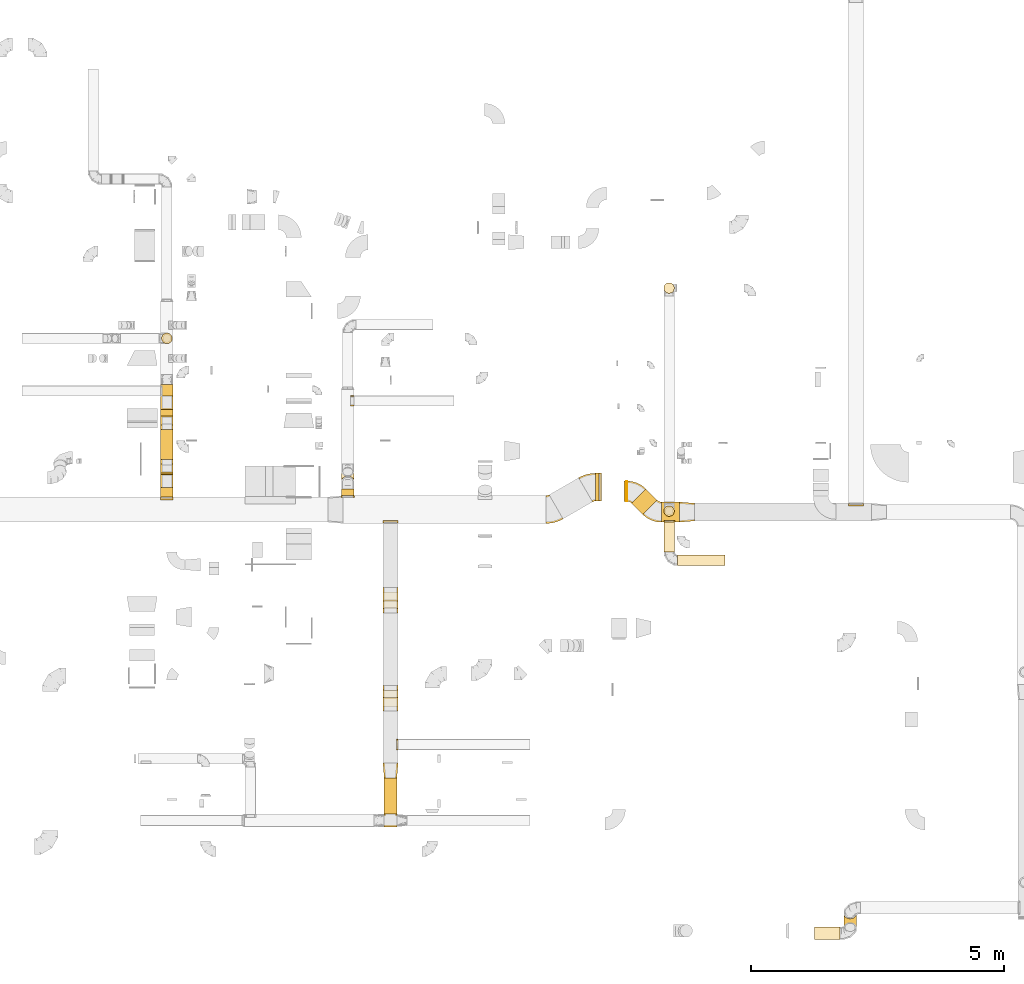
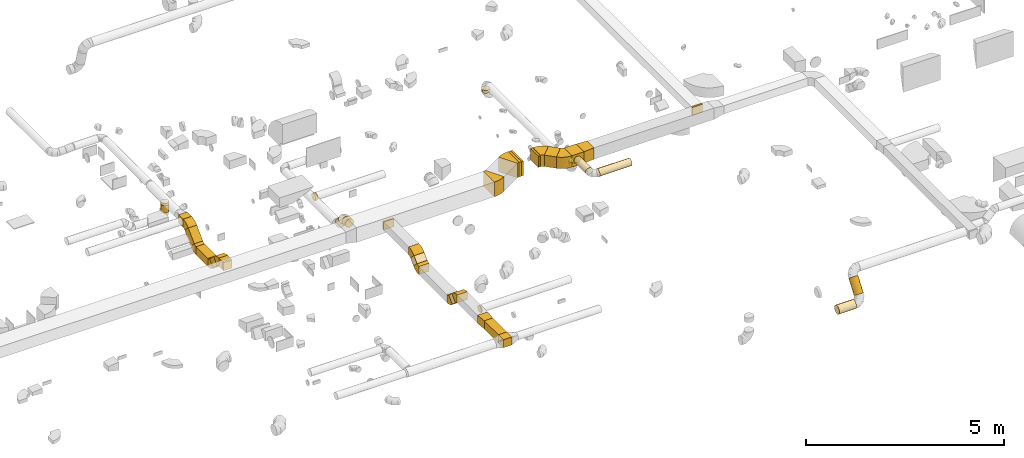
# One storey, part 3 of 62: 47 coverings.
"""IFC2X3 building model written with IfcOpenShell, lengths in millimetres."""

from ifc_helpers import new_model, entity, si_unit, converted_unit, derived_unit, direction, frame, frame_2d, origin, origin_2d_with_axis, place, context, subcontext, project, spatial, polyline, circle_curve, parameter, trimmed, segment, composite_curve, rectangle, circle, outline, extrude, element, save


model = new_model("IFC2X3")

# Units and contexts
model_context = context("Model", 3, precision=0.01, world=origin(), true_north=direction((6.12303176911189e-17, 1.0)))
body_context = subcontext(model_context, "Body", "Model", "MODEL_VIEW")
ifc_project = project(units=[si_unit("LENGTHUNIT", "METRE", prefix="MILLI"), si_unit("AREAUNIT", "SQUARE_METRE"), si_unit("VOLUMEUNIT", "CUBIC_METRE"), converted_unit("PLANEANGLEUNIT", "DEGREE", entity("IfcRatioMeasure", 0.0174532925199433), si_unit("PLANEANGLEUNIT", "RADIAN"), dimensions=[0, 0, 0, 0, 0, 0, 0]), si_unit("MASSUNIT", "GRAM", prefix="KILO"), derived_unit("MASSDENSITYUNIT", [(si_unit("MASSUNIT", "GRAM", prefix="KILO"), 1), (si_unit("LENGTHUNIT", "METRE"), -3)]), derived_unit("MOMENTOFINERTIAUNIT", [(si_unit("LENGTHUNIT", "METRE"), 4)]), si_unit("TIMEUNIT", "SECOND"), si_unit("FREQUENCYUNIT", "HERTZ"), si_unit("THERMODYNAMICTEMPERATUREUNIT", "DEGREE_CELSIUS"), derived_unit("THERMALTRANSMITTANCEUNIT", [(si_unit("MASSUNIT", "GRAM", prefix="KILO"), 1), (si_unit("THERMODYNAMICTEMPERATUREUNIT", "KELVIN"), -1), (si_unit("TIMEUNIT", "SECOND"), -3)]), derived_unit("VOLUMETRICFLOWRATEUNIT", [(si_unit("LENGTHUNIT", "METRE"), 3), (si_unit("TIMEUNIT", "SECOND"), -1)]), derived_unit("MASSFLOWRATEUNIT", [(si_unit("MASSUNIT", "GRAM", prefix="KILO"), 1), (si_unit("TIMEUNIT", "SECOND"), -1)]), derived_unit("ROTATIONALFREQUENCYUNIT", [(si_unit("TIMEUNIT", "SECOND"), -1)]), si_unit("ELECTRICCURRENTUNIT", "AMPERE"), si_unit("ELECTRICVOLTAGEUNIT", "VOLT"), si_unit("POWERUNIT", "WATT"), si_unit("FORCEUNIT", "NEWTON", prefix="KILO"), si_unit("ILLUMINANCEUNIT", "LUX"), si_unit("LUMINOUSFLUXUNIT", "LUMEN"), si_unit("LUMINOUSINTENSITYUNIT", "CANDELA"), derived_unit("USERDEFINED", [(si_unit("MASSUNIT", "GRAM", prefix="KILO"), -1), (si_unit("LENGTHUNIT", "METRE"), -2), (si_unit("TIMEUNIT", "SECOND"), 3), (si_unit("LUMINOUSFLUXUNIT", "LUMEN"), 1)]), derived_unit("LINEARVELOCITYUNIT", [(si_unit("LENGTHUNIT", "METRE"), 1), (si_unit("TIMEUNIT", "SECOND"), -1)]), si_unit("PRESSUREUNIT", "PASCAL"), derived_unit("USERDEFINED", [(si_unit("LENGTHUNIT", "METRE"), -2), (si_unit("MASSUNIT", "GRAM", prefix="KILO"), 1), (si_unit("TIMEUNIT", "SECOND"), -2)]), derived_unit("LINEARFORCEUNIT", [(si_unit("MASSUNIT", "GRAM", prefix="KILO"), 1), (si_unit("LENGTHUNIT", "METRE"), 1), (si_unit("TIMEUNIT", "SECOND"), -2), (si_unit("LENGTHUNIT", "METRE"), -1)]), derived_unit("PLANARFORCEUNIT", [(si_unit("MASSUNIT", "GRAM", prefix="KILO"), 1), (si_unit("LENGTHUNIT", "METRE"), 1), (si_unit("TIMEUNIT", "SECOND"), -2), (si_unit("LENGTHUNIT", "METRE"), -2)])], contexts=[model_context])

# Site, building, storey
site_placement = place(None, origin())
site = spatial("IfcSite", under=ifc_project, at=site_placement, CompositionType="ELEMENT")
building_placement = place(site_placement, origin())
building = spatial("IfcBuilding", under=site, at=building_placement, CompositionType="ELEMENT")
storey_placement = place(building_placement, frame((0.0, 0.0, 24000.0)))
storey = spatial("IfcBuildingStorey", under=building, at=storey_placement, CompositionType="ELEMENT", Elevation=24000.0)

# Coverings
covering_1_placement = place(storey_placement, frame((59305.64, 9093.57, 3325.0)))
element("IfcCovering", 1, at=covering_1_placement, inside=storey, PredefinedType="INSULATION", context=body_context, shape_type="SweptSolid", body=[
    extrude(rectangle(XDim=550.000000000001, YDim=51.0960000000016, at=origin_2d_with_axis()), frame((25.55, 275.0, 0.0), z_axis=(0.0, 0.0, 1.0), x_axis=(0.0, -1.0, 0.0)), (0.0, 0.0, 1.0), 450.000000000002),
])
covering_2_placement = place(storey_placement, frame((59237.24, 9093.57, 3325.0)))
element("IfcCovering", 2, at=covering_2_placement, inside=storey, PredefinedType="INSULATION", context=body_context, shape_type="SweptSolid", body=[
    extrude(rectangle(XDim=68.403733792958, YDim=550.000000000001, at=origin_2d_with_axis()), frame((34.2, 275.0, 0.0), z_axis=(0.0, 0.0, 1.0), x_axis=(-1.0, 0.0, 0.0)), (0.0, 0.0, 1.0), 450.000000000002),
])
covering_3_placement = place(storey_placement, frame((55054.59, 2900.97, 3425.0)))
element("IfcCovering", 3, at=covering_3_placement, inside=storey, PredefinedType="INSULATION", context=body_context, shape_type="SweptSolid", body=[
    extrude(rectangle(XDim=711.276811598477, YDim=249.999999999995, at=origin_2d_with_axis()), frame((125.0, 355.64, 0.0), z_axis=(0.0, 0.0, 1.0), x_axis=(0.0, -1.0, 0.0)), (0.0, 0.0, 1.0), 250.000000000004),
])
covering_4_placement = place(storey_placement, frame((55029.59, 3612.24, 3425.0)))
element("IfcCovering", 4, at=covering_4_placement, inside=storey, PredefinedType="INSULATION", context=body_context, shape_type="SweptSolid", body=[
    extrude(outline(polyline([(-139.1, -137.03), (161.94, -137.03), (137.03, 161.94), (-159.86, 112.11), (-139.1, -137.03)])), frame((150.0, 150.0, 0.0), z_axis=(0.0, 0.0, 1.0), x_axis=(0.0830454798539784, 0.99654575824486, 0.0)), (0.0, 0.0, 1.0), 250.000000000004),
])
covering_5_placement = place(storey_placement, frame((55029.59, 8654.98, 3425.0)))
element("IfcCovering", 5, at=covering_5_placement, inside=storey, PredefinedType="INSULATION", context=body_context, shape_type="SweptSolid", body=[
    extrude(rectangle(XDim=300.000000000001, YDim=51.096000000008, at=origin_2d_with_axis()), frame((150.0, 25.55, 0.0)), (0.0, 0.0, 1.0), 250.000000000004),
])
covering_6_placement = place(storey_placement, frame((55029.59, 6967.61, 3234.83)))
element("IfcCovering", 6, at=covering_6_placement, inside=storey, PredefinedType="INSULATION", context=body_context, shape_type="SweptSolid", body=[
    extrude(rectangle(XDim=217.157287525396, YDim=249.999999999997, at=origin_2d_with_axis()), frame((0.0, 165.17, 165.17), z_axis=(1.0, 0.0, 0.0), x_axis=(0.0, -0.707106781186548, -0.707106781186548)), (0.0, 0.0, 1.0), 300.000000000001),
])
covering_7_placement = place(storey_placement, frame((55029.59, 5029.69, 3234.83)))
element("IfcCovering", 7, at=covering_7_placement, inside=storey, PredefinedType="INSULATION", context=body_context, shape_type="SweptSolid", body=[
    extrude(rectangle(XDim=217.157287525369, YDim=250.0, at=origin_2d_with_axis()), frame((0.0, 165.17, 165.17), z_axis=(1.0, 0.0, 0.0), x_axis=(0.0, 0.7071067811865, -0.707106781186595)), (0.0, 0.0, 1.0), 300.00000000001),
])
covering_8_placement = place(storey_placement, frame((55298.49, 4170.65, 3443.4)))
element("IfcCovering", 8, at=covering_8_placement, inside=storey, PredefinedType="INSULATION", context=body_context, shape_type="SweptSolid", body=[
    extrude(circle(Radius=105.0, at=origin_2d_with_axis()), frame((0.0, 106.6, 106.6), z_axis=(1.0, 0.0, 0.0), x_axis=(0.0, 1.0, 0.0)), (0.0, 0.0, 1.0), 26.0960000002065),
])
covering_9_placement = place(storey_placement, frame((50631.62, 9913.65, 3075.0)))
element("IfcCovering", 9, at=covering_9_placement, inside=storey, PredefinedType="INSULATION", context=body_context, shape_type="SweptSolid", body=[
    extrude(rectangle(XDim=597.695447254163, YDim=249.999999999995, at=origin_2d_with_axis()), frame((125.0, 298.85, 0.0), z_axis=(0.0, 0.0, 1.0), x_axis=(0.0, 1.0, 0.0)), (0.0, 0.0, 1.0), 250.000000000004),
])
covering_10_placement = place(storey_placement, frame((50631.62, 9118.88, 3425.0)))
element("IfcCovering", 10, at=covering_10_placement, inside=storey, PredefinedType="INSULATION", context=body_context, shape_type="SweptSolid", body=[
    extrude(rectangle(XDim=250.000000000004, YDim=51.0960000000427, at=origin_2d_with_axis()), frame((125.0, 25.55, 0.0), z_axis=(0.0, 0.0, 1.0), x_axis=(-1.0, 0.0, 0.0)), (0.0, 0.0, 1.0), 250.000000000004),
])
covering_11_placement = place(storey_placement, frame((50631.62, 9169.98, 3425.0)))
element("IfcCovering", 11, at=covering_11_placement, inside=storey, PredefinedType="INSULATION", context=body_context, shape_type="SweptSolid", body=[
    extrude(rectangle(XDim=186.566609406722, YDim=249.999999999995, at=origin_2d_with_axis()), frame((125.0, 93.28, 0.0), z_axis=(0.0, 0.0, 1.0), x_axis=(0.0, 1.0, 0.0)), (0.0, 0.0, 1.0), 250.000000000004),
])
covering_12_placement = place(storey_placement, frame((50631.62, 9444.93, 3184.83)))
element("IfcCovering", 12, at=covering_12_placement, inside=storey, PredefinedType="INSULATION", context=body_context, shape_type="SweptSolid", body=[
    extrude(rectangle(XDim=249.999999999998, YDim=249.999999999995, at=frame_2d((0.0, 0.0), x_axis=(0.0, 1.0))), frame((125.0, 291.94, 88.39), z_axis=(0.0, -0.707106781186508, 0.707106781186587), x_axis=(-1.0, 0.0, 0.0)), (0.0, 0.0, 1.0), 287.867965643983),
])
covering_13_placement = place(storey_placement, frame((50631.62, 11168.45, 3525.0)))
element("IfcCovering", 13, at=covering_13_placement, inside=storey, PredefinedType="INSULATION", context=body_context, shape_type="SweptSolid", body=[
    extrude(rectangle(XDim=227.123541719797, YDim=249.999999999995, at=origin_2d_with_axis()), frame((125.0, 113.56, 0.0), z_axis=(0.0, 0.0, 1.0), x_axis=(0.0, -1.0, 0.0)), (0.0, 0.0, 1.0), 250.000000000004),
])
covering_14_placement = place(storey_placement, frame((50631.62, 10599.73, 3184.83)))
element("IfcCovering", 14, at=covering_14_placement, inside=storey, PredefinedType="INSULATION", context=body_context, shape_type="SweptSolid", body=[
    extrude(rectangle(XDim=249.999999999995, YDim=249.999999999995, at=frame_2d((0.0, 0.0), x_axis=(0.0, 1.0))), frame((125.0, 88.39, 88.39), z_axis=(0.0, 0.707106781186517, 0.707106781186578), x_axis=(1.0, 0.0, 0.0)), (0.0, 0.0, 1.0), 429.289321881387),
])
covering_15_placement = place(storey_placement, frame((50650.03, 12203.45, 3300.0)))
element("IfcCovering", 15, at=covering_15_placement, inside=storey, PredefinedType="INSULATION", context=body_context, shape_type="SweptSolid", body=[
    extrude(circle(Radius=105.0, at=origin_2d_with_axis()), frame((106.6, 106.6, 0.0), z_axis=(0.0, 0.0, 1.0), x_axis=(0.0, -1.0, 0.0)), (0.0, 0.0, 1.0), 230.000000000021),
])
covering_16_placement = place(storey_placement, frame((50650.03, 12203.45, 3530.0)))
element("IfcCovering", 16, at=covering_16_placement, inside=storey, PredefinedType="INSULATION", context=body_context, shape_type="SweptSolid", body=[
    extrude(circle(Radius=105.0, at=origin_2d_with_axis()), frame((106.6, 106.6, 0.0), z_axis=(0.0, 0.0, 1.0), x_axis=(0.0, 1.0, 0.0)), (0.0, 0.0, 1.0), 66.0960000000068),
])
covering_17_placement = place(storey_placement, frame((54206.92, 9389.54, 3189.5)))
element("IfcCovering", 17, at=covering_17_placement, inside=storey, PredefinedType="INSULATION", context=body_context, shape_type="SweptSolid", body=[
    extrude(circle(Radius=125.0, at=origin_2d_with_axis()), frame((126.6, 97.35, 302.72), z_axis=(0.0, 0.642787609686537, -0.76604444311898), x_axis=(1.0, 0.0, 0.0)), (0.0, 0.0, 1.0), 288.206572271397),
])
covering_18_placement = place(storey_placement, frame((54206.92, 9194.98, 3437.07)))
element("IfcCovering", 18, at=covering_18_placement, inside=storey, PredefinedType="INSULATION", context=body_context, shape_type="SweptSolid", body=[
    extrude(circle(Radius=125.0, at=origin_2d_with_axis()), frame((126.6, 0.0, 126.6), z_axis=(0.0, 1.0, 0.0), x_axis=(-1.0, 0.0, 0.0)), (0.0, 0.0, 1.0), 138.700860216017),
])
covering_19_placement = place(storey_placement, frame((54206.92, 9168.88, 3437.07)))
element("IfcCovering", 19, at=covering_19_placement, inside=storey, PredefinedType="INSULATION", context=body_context, shape_type="SweptSolid", body=[
    extrude(circle(Radius=125.0, at=origin_2d_with_axis()), frame((126.6, 0.0, 126.6), z_axis=(0.0, 1.0, 0.0), x_axis=(-1.0, 0.0, 0.0)), (0.0, 0.0, 1.0), 26.0959999999942),
])
covering_20_placement = place(storey_placement, frame((60539.45, 8675.02, 3425.0)))
element("IfcCovering", 20, at=covering_20_placement, inside=storey, PredefinedType="INSULATION", context=body_context, shape_type="SweptSolid", body=[
    extrude(rectangle(XDim=352.280592228734, YDim=400.0, at=origin_2d_with_axis()), frame((176.14, 200.0, 0.0), z_axis=(0.0, 0.0, 1.0), x_axis=(-1.0, 0.0, 0.0)), (0.0, 0.0, 1.0), 349.999999999998),
])
covering_21_placement = place(storey_placement, frame((60891.73, 8675.02, 3425.0)))
element("IfcCovering", 21, at=covering_21_placement, inside=storey, PredefinedType="INSULATION", context=body_context, shape_type="SweptSolid", body=[
    extrude(outline(polyline([(-166.09, -186.85), (134.95, -186.85), (164.01, 161.94), (-132.87, 211.77), (-166.09, -186.85)])), frame((150.0, 200.0, 0.0), z_axis=(0.0, 0.0, 1.0), x_axis=(0.996545758244898, 0.0830454798535232, 0.0)), (0.0, 0.0, 1.0), 349.999999999998),
])
covering_22_placement = place(storey_placement, frame((59845.64, 9088.12, 3425.0)))
element("IfcCovering", 22, at=covering_22_placement, inside=storey, PredefinedType="INSULATION", context=body_context, shape_type="SweptSolid", body=[
    extrude(rectangle(XDim=11.4684169262546, YDim=400.0, at=origin_2d_with_axis()), frame((5.73, 200.0, 0.0), z_axis=(0.0, 0.0, 1.0), x_axis=(-1.0, 0.0, 0.0)), (0.0, 0.0, 1.0), 349.999999999998),
])
covering_23_placement = place(storey_placement, frame((59945.5, 8828.79, 3425.0)))
element("IfcCovering", 23, at=covering_23_placement, inside=storey, PredefinedType="INSULATION", context=body_context, shape_type="SweptSolid", body=[
    extrude(rectangle(XDim=314.972807073821, YDim=400.000000000007, at=origin_2d_with_axis()), frame((252.78, 252.78, 0.0), z_axis=(0.0, 0.0, 1.0), x_axis=(-0.707106781186534, 0.707106781186561, 0.0)), (0.0, 0.0, 1.0), 349.999999999998),
])
covering_24_placement = place(storey_placement, frame((59794.55, 9088.12, 3425.0)))
element("IfcCovering", 24, at=covering_24_placement, inside=storey, PredefinedType="INSULATION", context=body_context, shape_type="SweptSolid", body=[
    extrude(rectangle(XDim=400.0, YDim=51.0960000000016, at=origin_2d_with_axis()), frame((25.55, 200.0, 0.0), z_axis=(0.0, 0.0, 1.0), x_axis=(0.0, 1.0, 0.0)), (0.0, 0.0, 1.0), 349.999999999998),
])
covering_25_placement = place(storey_placement, frame((60582.25, 8789.03, 3320.0)))
element("IfcCovering", 25, at=covering_25_placement, inside=storey, PredefinedType="INSULATION", context=body_context, shape_type="SweptSolid", body=[
    extrude(circle(Radius=105.0, at=origin_2d_with_axis()), frame((106.6, 106.6, 0.0), z_axis=(0.0, 0.0, 1.0), x_axis=(-1.0, 0.0, 0.0)), (0.0, 0.0, 1.0), 109.999999999901),
])
covering_26_placement = place(storey_placement, frame((60582.25, 8789.03, 3430.0)))
element("IfcCovering", 26, at=covering_26_placement, inside=storey, PredefinedType="INSULATION", context=body_context, shape_type="SweptSolid", body=[
    extrude(circle(Radius=105.0, at=origin_2d_with_axis()), frame((106.6, 106.6, 0.0), z_axis=(0.0, 0.0, 1.0), x_axis=(-1.0, 0.0, 0.0)), (0.0, 0.0, 1.0), 26.0960000002065),
])
covering_27_placement = place(storey_placement, frame((60856.21, 7819.07, 3493.4)))
element("IfcCovering", 27, at=covering_27_placement, inside=storey, PredefinedType="INSULATION", context=body_context, shape_type="SweptSolid", body=[
    extrude(circle(Radius=105.0, at=origin_2d_with_axis()), frame((0.0, 106.6, 106.6), z_axis=(1.0, 0.0, 0.0), x_axis=(0.0, -1.0, 0.0)), (0.0, 0.0, 1.0), 939.375000000018),
])
covering_28_placement = place(storey_placement, frame((60589.62, 8085.66, 3493.4)))
element("IfcCovering", 28, at=covering_28_placement, inside=storey, PredefinedType="INSULATION", context=body_context, shape_type="SweptSolid", body=[
    extrude(circle(Radius=105.0, at=origin_2d_with_axis()), frame((106.6, 0.0, 106.6), z_axis=(0.0, 1.0, 0.0), x_axis=(-1.0, 0.0, 0.0)), (0.0, 0.0, 1.0), 594.360142446069),
])
covering_29_placement = place(storey_placement, frame((60589.62, 8680.02, 3493.4)))
element("IfcCovering", 29, at=covering_29_placement, inside=storey, PredefinedType="INSULATION", context=body_context, shape_type="SweptSolid", body=[
    extrude(circle(Radius=105.0, at=origin_2d_with_axis()), frame((106.6, 0.0, 106.6), z_axis=(0.0, 1.0, 0.0), x_axis=(1.0, 0.0, 0.0)), (0.0, 0.0, 1.0), 26.0960000000365),
])
covering_30_placement = place(storey_placement, frame((64232.65, 8993.93, 3525.0)))
element("IfcCovering", 30, at=covering_30_placement, inside=storey, PredefinedType="INSULATION", context=body_context, shape_type="SweptSolid", body=[
    extrude(rectangle(XDim=51.0960000000113, YDim=300.000000000001, at=origin_2d_with_axis()), frame((150.0, 25.55, 0.0), z_axis=(0.0, 0.0, 1.0), x_axis=(0.0, -1.0, 0.0)), (0.0, 0.0, 1.0), 250.000000000004),
])
covering_31_placement = place(storey_placement, frame((55054.59, 2650.97, 3425.0)))
element("IfcCovering", 31, at=covering_31_placement, inside=storey, PredefinedType="INSULATION", context=body_context, shape_type="SweptSolid", body=[
    extrude(rectangle(XDim=249.999999999998, YDim=250.000000000004, at=origin_2d_with_axis()), frame((125.0, 125.0, 0.0), z_axis=(0.0, 0.0, 1.0), x_axis=(0.0, -1.0, 0.0)), (0.0, 0.0, 1.0), 250.000000000004),
])
covering_32_placement = place(storey_placement, frame((64143.27, 557.6, 2987.12)))
element("IfcCovering", 32, at=covering_32_placement, inside=storey, PredefinedType="INSULATION", context=body_context, shape_type="SweptSolid", body=[
    extrude(circle(Radius=125.0, at=origin_2d_with_axis()), frame((126.6, 102.85, 74.89), z_axis=(0.0, 0.586367683700161, 0.810045023138905), x_axis=(1.0, 0.0, 0.0)), (0.0, 0.0, 1.0), 464.149497873041),
])
covering_33_placement = place(storey_placement, frame((63567.37, 416.58, 2773.4)))
element("IfcCovering", 33, at=covering_33_placement, inside=storey, PredefinedType="INSULATION", context=body_context, shape_type="SweptSolid", body=[
    extrude(circle(Radius=125.0, at=origin_2d_with_axis()), frame((0.0, 126.6, 126.6), z_axis=(1.0, 0.0, 0.0), x_axis=(0.0, 1.0, 0.0)), (0.0, 0.0, 1.0), 502.500000000024),
])
covering_34_placement = place(storey_placement, frame((60582.25, 13199.03, 2910.0)))
element("IfcCovering", 34, at=covering_34_placement, inside=storey, PredefinedType="INSULATION", context=body_context, shape_type="SweptSolid", body=[
    extrude(circle(Radius=105.0, at=origin_2d_with_axis()), frame((106.6, 106.6, 0.0)), (0.0, 0.0, 1.0), 90.0000000000272),
])
covering_35_placement = place(storey_placement, frame((54387.42, 10971.22, 3093.4)))
element("IfcCovering", 35, at=covering_35_placement, inside=storey, PredefinedType="INSULATION", context=body_context, shape_type="SweptSolid", body=[
    extrude(circle(Radius=105.0, at=origin_2d_with_axis()), frame((0.0, 106.6, 106.6), z_axis=(1.0, 0.0, 0.0), x_axis=(0.0, 1.0, 0.0)), (0.0, 0.0, 1.0), 66.0959999999981),
])
covering_36_placement = place(storey_placement, frame((58252.96, 8648.38, 3325.0)))
element("IfcCovering", 36, at=covering_36_placement, inside=storey, PredefinedType="INSULATION", context=body_context, shape_type="SweptSolid", body=[
    extrude(outline(composite_curve([segment(polyline([(-264.95, 37.5), (211.36, -237.5)]), True, "CONTINUOUS"), segment(trimmed(circle_curve(frame_2d((-373.21, 100.0), x_axis=(1.0, 0.0)), 675.0), [parameter(330.0)], [parameter(0.0)], True, "PARAMETER"), True, "CONTINUOUS"), segment(polyline([(301.79, 100.0), (-248.21, 100.0)]), True, "CONTINUOUS"), segment(trimmed(circle_curve(frame_2d((-373.21, 100.0), x_axis=(1.0, 0.0)), 125.0), [parameter(330.0)], [parameter(360.0)], True, "PARAMETER"), False, "CONTINUOUS")], self_intersect=False)), frame((101.6, 303.39, 0.0), z_axis=(0.0, 0.0, -1.0), x_axis=(0.0, -1.0, 0.0)), (0.0, 0.0, -1.0), 450.000000000002),
])
covering_37_placement = place(storey_placement, frame((58898.14, 9075.23, 3325.0)))
element("IfcCovering", 37, at=covering_37_placement, inside=storey, PredefinedType="INSULATION", context=body_context, shape_type="SweptSolid", body=[
    extrude(outline(composite_curve([segment(polyline([(-264.95, 37.5), (211.36, -237.5)]), True, "CONTINUOUS"), segment(trimmed(circle_curve(frame_2d((-373.21, 100.0), x_axis=(1.0, 0.0)), 675.0), [parameter(330.0)], [parameter(0.0)], True, "PARAMETER"), True, "CONTINUOUS"), segment(polyline([(301.79, 100.0), (-248.21, 100.0)]), True, "CONTINUOUS"), segment(trimmed(circle_curve(frame_2d((-373.21, 100.0), x_axis=(1.0, 0.0)), 125.0), [parameter(330.0)], [parameter(360.0)], True, "PARAMETER"), False, "CONTINUOUS")], self_intersect=False)), frame((239.1, 266.55, 0.0), z_axis=(0.0, 0.0, -1.0), x_axis=(0.0, 1.0, 0.0)), (0.0, 0.0, -1.0), 450.000000000002),
])
covering_38_placement = place(storey_placement, frame((55029.59, 7119.57, 3386.79)))
element("IfcCovering", 38, at=covering_38_placement, inside=storey, PredefinedType="INSULATION", context=body_context, shape_type="SweptSolid", body=[
    extrude(outline(composite_curve([segment(polyline([(-125.0, 0.0), (51.78, -176.78)]), True, "CONTINUOUS"), segment(trimmed(circle_curve(frame_2d((-213.39, 88.39), x_axis=(1.0, 0.0)), 375.0), [parameter(315.0)], [parameter(0.0)], True, "PARAMETER"), True, "CONTINUOUS"), segment(polyline([(161.61, 88.39), (-88.39, 88.39)]), True, "CONTINUOUS"), segment(trimmed(circle_curve(frame_2d((-213.39, 88.39), x_axis=(1.0, 0.0)), 125.0), [parameter(315.0)], [parameter(360.0)], True, "PARAMETER"), False, "CONTINUOUS")], self_intersect=False)), frame((0.0, 178.37, 126.6), z_axis=(-1.0, 0.0, 0.0), x_axis=(0.0, 0.0, 1.0)), (0.0, 0.0, -1.0), 300.000000000001),
])
covering_39_placement = place(storey_placement, frame((55029.59, 4939.71, 3386.79)))
element("IfcCovering", 39, at=covering_39_placement, inside=storey, PredefinedType="INSULATION", context=body_context, shape_type="SweptSolid", body=[
    extrude(outline(composite_curve([segment(polyline([(-88.39, -88.39), (161.61, -88.39)]), True, "CONTINUOUS"), segment(trimmed(circle_curve(frame_2d((-213.39, -88.39), x_axis=(0.707106781186553, 0.707106781186553)), 375.0), [parameter(315.0)], [parameter(0.0)], True, "PARAMETER"), True, "CONTINUOUS"), segment(polyline([(51.78, 176.78), (-125.0, 0.0)]), True, "CONTINUOUS"), segment(trimmed(circle_curve(frame_2d((-213.39, -88.39), x_axis=(0.707106781186553, 0.707106781186553)), 125.0), [parameter(315.0)], [parameter(360.0)], True, "PARAMETER"), False, "CONTINUOUS")], self_intersect=False)), frame((0.0, 89.98, 126.6), z_axis=(1.0, 0.0, 0.0), x_axis=(0.0, 0.707106781186552, 0.707106781186543)), (0.0, 0.0, 1.0), 300.000000000001),
])
covering_40_placement = place(storey_placement, frame((55029.59, 6877.63, 3123.4)))
element("IfcCovering", 40, at=covering_40_placement, inside=storey, PredefinedType="INSULATION", context=body_context, shape_type="SweptSolid", body=[
    extrude(outline(composite_curve([segment(polyline([(-88.39, -88.39), (161.61, -88.39)]), True, "CONTINUOUS"), segment(trimmed(circle_curve(frame_2d((-213.39, -88.39), x_axis=(0.707106781186553, 0.707106781186553)), 375.0), [parameter(315.0)], [parameter(0.0)], True, "PARAMETER"), True, "CONTINUOUS"), segment(polyline([(51.78, 176.78), (-125.0, 0.0)]), True, "CONTINUOUS"), segment(trimmed(circle_curve(frame_2d((-213.39, -88.39), x_axis=(0.707106781186553, 0.707106781186553)), 125.0), [parameter(315.0)], [parameter(360.0)], True, "PARAMETER"), False, "CONTINUOUS")], self_intersect=False)), frame((0.0, 89.98, 163.21), z_axis=(1.0, 0.0, 0.0), x_axis=(0.0, 0.0, -1.0)), (0.0, 0.0, 1.0), 300.000000000001),
])
covering_41_placement = place(storey_placement, frame((55029.59, 5181.65, 3123.4)))
element("IfcCovering", 41, at=covering_41_placement, inside=storey, PredefinedType="INSULATION", context=body_context, shape_type="SweptSolid", body=[
    extrude(outline(composite_curve([segment(polyline([(-125.0, 0.0), (51.78, -176.78)]), True, "CONTINUOUS"), segment(trimmed(circle_curve(frame_2d((-213.39, 88.39), x_axis=(1.0, 0.0)), 375.0), [parameter(315.0)], [parameter(0.0)], True, "PARAMETER"), True, "CONTINUOUS"), segment(polyline([(161.61, 88.39), (-88.39, 88.39)]), True, "CONTINUOUS"), segment(trimmed(circle_curve(frame_2d((-213.39, 88.39), x_axis=(1.0, 0.0)), 125.0), [parameter(315.0)], [parameter(360.0)], True, "PARAMETER"), False, "CONTINUOUS")], self_intersect=False)), frame((0.0, 178.37, 163.21), z_axis=(-1.0, 0.0, 0.0), x_axis=(0.0, -0.707106781186576, -0.707106781186519)), (0.0, 0.0, -1.0), 300.000000000001),
])
covering_42_placement = place(storey_placement, frame((50631.62, 9354.95, 3386.79)))
element("IfcCovering", 42, at=covering_42_placement, inside=storey, PredefinedType="INSULATION", context=body_context, shape_type="SweptSolid", body=[
    extrude(outline(composite_curve([segment(polyline([(-88.39, -88.39), (161.61, -88.39)]), True, "CONTINUOUS"), segment(trimmed(circle_curve(frame_2d((-213.39, -88.39), x_axis=(0.707106781186553, 0.707106781186553)), 375.0), [parameter(315.0)], [parameter(0.0)], True, "PARAMETER"), True, "CONTINUOUS"), segment(polyline([(51.78, 176.78), (-125.0, 0.0)]), True, "CONTINUOUS"), segment(trimmed(circle_curve(frame_2d((-213.39, -88.39), x_axis=(0.707106781186553, 0.707106781186553)), 125.0), [parameter(315.0)], [parameter(360.0)], True, "PARAMETER"), False, "CONTINUOUS")], self_intersect=False)), frame((0.0, 89.98, 126.6), z_axis=(1.0, 0.0, 0.0), x_axis=(0.0, 0.707106781186552, 0.707106781186543)), (0.0, 0.0, 1.0), 249.999999999995),
])
covering_43_placement = place(storey_placement, frame((50631.62, 10901.69, 3486.79)))
element("IfcCovering", 43, at=covering_43_placement, inside=storey, PredefinedType="INSULATION", context=body_context, shape_type="SweptSolid", body=[
    extrude(outline(composite_curve([segment(polyline([(-125.0, 0.0), (51.78, -176.78)]), True, "CONTINUOUS"), segment(trimmed(circle_curve(frame_2d((-213.39, 88.39), x_axis=(1.0, 0.0)), 375.0), [parameter(315.0)], [parameter(0.0)], True, "PARAMETER"), True, "CONTINUOUS"), segment(polyline([(161.61, 88.39), (-88.39, 88.39)]), True, "CONTINUOUS"), segment(trimmed(circle_curve(frame_2d((-213.39, 88.39), x_axis=(1.0, 0.0)), 125.0), [parameter(315.0)], [parameter(360.0)], True, "PARAMETER"), False, "CONTINUOUS")], self_intersect=False)), frame((0.0, 178.37, 126.6), z_axis=(-1.0, 0.0, 0.0), x_axis=(0.0, 0.0, 1.0)), (0.0, 0.0, -1.0), 249.999999999995),
])
covering_44_placement = place(storey_placement, frame((50631.62, 9646.89, 3073.4)))
element("IfcCovering", 44, at=covering_44_placement, inside=storey, PredefinedType="INSULATION", context=body_context, shape_type="SweptSolid", body=[
    extrude(outline(composite_curve([segment(polyline([(-125.0, 0.0), (51.78, -176.78)]), True, "CONTINUOUS"), segment(trimmed(circle_curve(frame_2d((-213.39, 88.39), x_axis=(1.0, 0.0)), 375.0), [parameter(315.0)], [parameter(0.0)], True, "PARAMETER"), True, "CONTINUOUS"), segment(polyline([(161.61, 88.39), (-88.39, 88.39)]), True, "CONTINUOUS"), segment(trimmed(circle_curve(frame_2d((-213.39, 88.39), x_axis=(1.0, 0.0)), 125.0), [parameter(315.0)], [parameter(360.0)], True, "PARAMETER"), False, "CONTINUOUS")], self_intersect=False)), frame((0.0, 178.37, 163.21), z_axis=(-1.0, 0.0, 0.0), x_axis=(0.0, -0.707106781186583, -0.707106781186512)), (0.0, 0.0, -1.0), 249.999999999995),
])
covering_45_placement = place(storey_placement, frame((50631.62, 10509.75, 3073.4)))
element("IfcCovering", 45, at=covering_45_placement, inside=storey, PredefinedType="INSULATION", context=body_context, shape_type="SweptSolid", body=[
    extrude(outline(composite_curve([segment(polyline([(-88.39, -88.39), (161.61, -88.39)]), True, "CONTINUOUS"), segment(trimmed(circle_curve(frame_2d((-213.39, -88.39), x_axis=(0.707106781186553, 0.707106781186553)), 375.0), [parameter(315.0)], [parameter(0.0)], True, "PARAMETER"), True, "CONTINUOUS"), segment(polyline([(51.78, 176.78), (-125.0, 0.0)]), True, "CONTINUOUS"), segment(trimmed(circle_curve(frame_2d((-213.39, -88.39), x_axis=(0.707106781186553, 0.707106781186553)), 125.0), [parameter(315.0)], [parameter(360.0)], True, "PARAMETER"), False, "CONTINUOUS")], self_intersect=False)), frame((0.0, 89.98, 163.21), z_axis=(1.0, 0.0, 0.0), x_axis=(0.0, 0.0, -1.0)), (0.0, 0.0, 1.0), 249.999999999995),
])
covering_46_placement = place(storey_placement, frame((60166.62, 8673.43, 3425.0)))
element("IfcCovering", 46, at=covering_46_placement, inside=storey, PredefinedType="INSULATION", context=body_context, shape_type="SweptSolid", body=[
    extrude(outline(composite_curve([segment(polyline([(-189.02, 26.52), (93.83, -256.33)]), True, "CONTINUOUS"), segment(trimmed(circle_curve(frame_2d((-277.4, 114.9), x_axis=(1.0, 0.0)), 525.0), [parameter(315.0)], [parameter(0.0)], True, "PARAMETER"), True, "CONTINUOUS"), segment(polyline([(247.6, 114.9), (-152.4, 114.9)]), True, "CONTINUOUS"), segment(trimmed(circle_curve(frame_2d((-277.4, 114.9), x_axis=(1.0, 0.0)), 125.0), [parameter(315.0)], [parameter(360.0)], True, "PARAMETER"), False, "CONTINUOUS")], self_intersect=False)), frame((257.92, 249.19, 0.0), z_axis=(0.0, 0.0, -1.0), x_axis=(-0.70710678118655, -0.707106781186545, 0.0)), (0.0, 0.0, -1.0), 349.999999999998),
])
covering_47_placement = place(storey_placement, frame((59855.52, 9049.92, 3425.0)))
element("IfcCovering", 47, at=covering_47_placement, inside=storey, PredefinedType="INSULATION", context=body_context, shape_type="SweptSolid", body=[
    extrude(outline(composite_curve([segment(polyline([(-189.02, 26.52), (93.83, -256.33)]), True, "CONTINUOUS"), segment(trimmed(circle_curve(frame_2d((-277.4, 114.9), x_axis=(1.0, 0.0)), 525.0), [parameter(315.0)], [parameter(0.0)], True, "PARAMETER"), True, "CONTINUOUS"), segment(polyline([(247.6, 114.9), (-152.4, 114.9)]), True, "CONTINUOUS"), segment(trimmed(circle_curve(frame_2d((-277.4, 114.9), x_axis=(1.0, 0.0)), 125.0), [parameter(315.0)], [parameter(360.0)], True, "PARAMETER"), False, "CONTINUOUS")], self_intersect=False)), frame((116.5, 190.61, 0.0), z_axis=(0.0, 0.0, -1.0), x_axis=(0.707106781186564, 0.707106781186531, 0.0)), (0.0, 0.0, -1.0), 349.999999999998),
])

save(model, "model.ifc")
